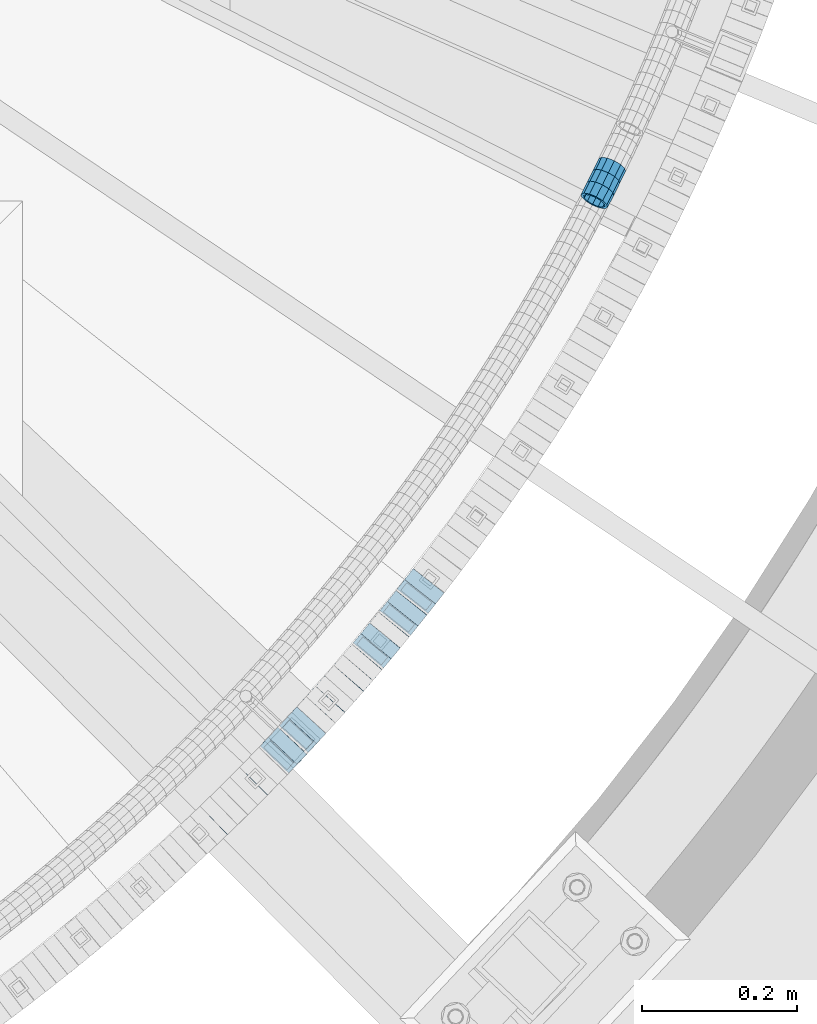
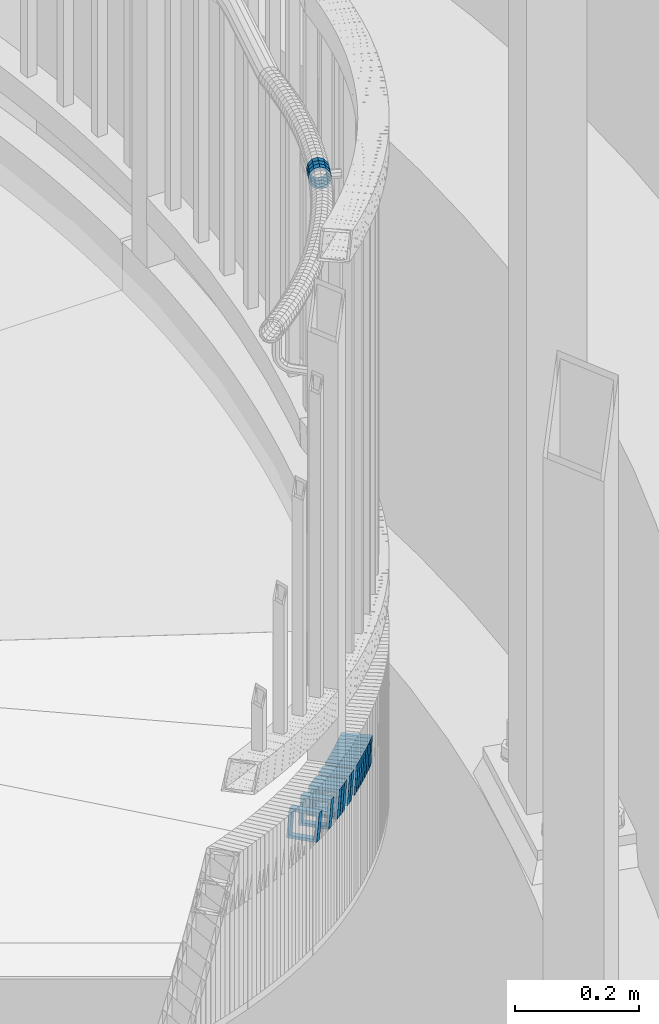
# One storey, part 777 of 975: 19 beams.
"""IFC2X3 building model written with IfcOpenShell, lengths in millimetres."""

from ifc_helpers import new_model, si_unit, frame, origin_with_axes, place, context, subcontext, project, spatial, faceted_brep, material, type_object, element, save


model = new_model("IFC2X3")

# Units and contexts
model_context = context("Model", 3, precision=1e-05, world=origin_with_axes())
body_context = subcontext(model_context, "Body", "Model", "MODEL_VIEW")
ifc_project = project(units=[si_unit("LENGTHUNIT", "METRE", prefix="MILLI"), si_unit("AREAUNIT", "SQUARE_METRE"), si_unit("VOLUMEUNIT", "CUBIC_METRE"), si_unit("MASSUNIT", "GRAM", prefix="KILO"), si_unit("TIMEUNIT", "SECOND"), si_unit("PLANEANGLEUNIT", "RADIAN"), si_unit("SOLIDANGLEUNIT", "STERADIAN"), si_unit("THERMODYNAMICTEMPERATUREUNIT", "DEGREE_CELSIUS"), si_unit("LUMINOUSINTENSITYUNIT", "LUMEN")], contexts=[model_context])

# Site, building, storey
site_placement = place(None, origin_with_axes())
site = spatial("IfcSite", under=ifc_project, at=site_placement, CompositionType="ELEMENT")
building_placement = place(site_placement, origin_with_axes())
building = spatial("IfcBuilding", under=site, at=building_placement, Name="Undefined", CompositionType="ELEMENT")
storey_placement = place(building_placement, origin_with_axes())
storey = spatial("IfcBuildingStorey", under=building, at=storey_placement, Name="Undefined", CompositionType="ELEMENT", Elevation=0.0)

# Beams
ifc_material = material()
beam_type_1 = type_object("IfcBeamType", PredefinedType="NOTDEFINED")
beam_1_placement = place(storey_placement, frame((37215.9977738311, 2133.37891237266, 3207.71060886619), z_axis=(-0.892098047383346, 0.451841868195966, -5.31599653186276e-13), x_axis=(0.429057443980011, 0.847113414960662, -0.313541977985444)))
element("IfcBeam", 1, at=beam_1_placement, inside=storey, type_object=beam_type_1, material=ifc_material, Name="WALL", context=body_context, shape_type="Brep", body=[
    faceted_brep([(-2.1246523829177e-07, -15.367000000002, 0.0), (-1.83998054126278e-07, -13.3082123799541, 7.68350000000009), (18.1793839279671, -13.3082123799522, 7.68350000002465), (18.1793839279671, -15.3669999999947, 2.5465851649642e-11), (-1.06232619145885e-07, -7.68349999999919, 13.3082123799559), (18.1793839279671, -7.68349999999555, 13.3082123799904), (-3.63797880709171e-12, 3.63797880709171e-12, 15.3670000000002), (18.1793839279708, 5.45696821063757e-12, 15.3670000000202), (1.06225343188271e-07, 7.68350000000646, 13.3082123799559), (18.1793839279781, 7.68350000000282, 13.3082123799613), (1.8399441614747e-07, 13.308212379965, 7.68350000000009), (18.1793839279853, 13.3082123799559, 7.68349999998827), (2.12461600312963e-07, 15.3670000000093, 0.0), (18.1793839279926, 15.3669999999984, -2.91038304567337e-11), (1.8399441614747e-07, 13.308212379965, -7.68350000000009), (18.1793839279962, 13.3082123799522, -7.68350000003193), (1.06225343188271e-07, 7.68350000000646, -13.3082123799559), (18.1793839279962, 7.68349999999737, -13.3082123799904), (-3.63797880709171e-12, 3.63797880709171e-12, -15.3670000000002), (18.1793839279962, -1.81898940354586e-12, -15.3670000000202), (-1.06232619145885e-07, -7.68349999999919, -13.3082123799559), (18.1793839279853, -7.68349999999737, -13.3082123799613), (-1.83998054126278e-07, -13.3082123799541, -7.68350000000009), (18.1793839279781, -13.3082123799522, -7.68349999998827), (-2.63386027654633e-07, -19.0500000000029, 0.0), (-2.28097633225843e-07, -16.4977839420972, -9.52499999999964), (18.1793839279744, -16.4977839420917, -9.52499999998327), (18.1793839279671, -19.0499999999938, 3.27418092638254e-11), (-1.31691194837913e-07, -9.52500000000146, -16.4977839420935), (18.179383927989, -9.52499999999964, -16.4977839421044), (-3.63797880709171e-12, 3.63797880709171e-12, -19.0500000000002), (18.1793839279999, -1.81898940354586e-12, -19.050000000032), (1.31687556859106e-07, 9.52500000000509, -16.4977839420935), (18.1793839280035, 9.524999999996, -16.4977839421408), (2.28097633225843e-07, 16.4977839421044, -9.52499999999964), (18.1793839279999, 16.4977839420899, -9.52500000004875), (2.63382389675826e-07, 19.0500000000138, 0.0), (18.1793839279962, 19.0499999999975, -3.27418092638254e-11), (2.28097633225843e-07, 16.4977839421044, 9.52499999999964), (18.1793839279853, 16.4977839420935, 9.52499999998327), (1.31687556859106e-07, 9.52500000000509, 16.4977839420935), (18.1793839279817, 9.52500000000146, 16.4977839420972), (-3.63797880709171e-12, 3.63797880709171e-12, 19.0500000000002), (18.1793839279708, 3.63797880709171e-12, 19.0500000000211), (-1.31691194837913e-07, -9.52500000000146, 16.4977839420935), (18.1793839279635, -9.52499999999418, 16.4977839421335), (-2.28097633225843e-07, -16.4977839420972, 9.52499999999964), (18.1793839279635, -16.4977839420881, 9.52500000004147)], [[[0, 1, 2, 3]], [[1, 4, 5, 2]], [[4, 6, 7, 5]], [[6, 8, 9, 7]], [[8, 10, 11, 9]], [[10, 12, 13, 11]], [[12, 14, 15, 13]], [[14, 16, 17, 15]], [[16, 18, 19, 17]], [[18, 20, 21, 19]], [[20, 22, 23, 21]], [[22, 0, 3, 23]], [[24, 25, 26, 27]], [[25, 28, 29, 26]], [[28, 30, 31, 29]], [[30, 32, 33, 31]], [[32, 34, 35, 33]], [[34, 36, 37, 35]], [[36, 38, 39, 37]], [[38, 40, 41, 39]], [[40, 42, 43, 41]], [[42, 44, 45, 43]], [[44, 46, 47, 45]], [[46, 24, 27, 47]], [[29, 31, 33, 35, 37, 39, 41, 43, 45, 47, 27, 26], [5, 7, 9, 11, 13, 15, 17, 19, 21, 23, 3, 2]], [[46, 44, 42, 40, 38, 36, 34, 32, 30, 28, 25, 24], [22, 20, 18, 16, 14, 12, 10, 8, 6, 4, 1, 0]]]),
])
beam_2_placement = place(storey_placement, frame((37223.9087635079, 2148.82953871151, 3201.97957507688), z_axis=(-0.897875826965735, 0.440248792560067, 1.23243353300495e-10), x_axis=(0.418766152969419, 0.85406254893795, -0.308564533977587)))
element("IfcBeam", 2, at=beam_2_placement, inside=storey, type_object=beam_type_1, material=ifc_material, Name="WALL", context=body_context, shape_type="Brep", body=[
    faceted_brep([(-2.1246523829177e-07, -15.367000000002, 0.0), (-1.83998054126278e-07, -13.3082123799541, 7.68350000000009), (18.1485536614346, -13.3082123799704, 7.68349999991551), (18.1485536614382, -15.3670000000166, -8.73114913702011e-11), (-1.06232619145885e-07, -7.68349999999919, 13.3082123799559), (18.1485536614236, -7.68350000001192, 13.3082123798922), (-3.63797880709171e-12, 3.63797880709171e-12, 15.3670000000002), (18.1485536614127, -1.09139364212751e-11, 15.3669999999547), (1.06225343188271e-07, 7.68350000000646, 13.3082123799559), (18.1485536614018, 7.68349999999191, 13.3082123799322), (1.8399441614747e-07, 13.308212379965, 7.68350000000009), (18.1485536613945, 13.3082123799504, 7.68349999999191), (2.12461600312963e-07, 15.3670000000093, 0.0), (18.1485536613945, 15.3669999999947, -3.63797880709171e-12), (1.8399441614747e-07, 13.308212379965, -7.68350000000009), (18.1485536613982, 13.3082123799504, -7.68350000000646), (1.06225343188271e-07, 7.68350000000646, -13.3082123799559), (18.1485536614091, 7.68349999999009, -13.3082123799832), (-3.63797880709171e-12, 3.63797880709171e-12, -15.3670000000002), (18.1485536614164, -1.09139364212751e-11, -15.3670000000493), (-1.06232619145885e-07, -7.68349999999919, -13.3082123799559), (18.1485536614273, -7.68350000001374, -13.3082123800305), (-1.83998054126278e-07, -13.3082123799541, -7.68350000000009), (18.1485536614346, -13.3082123799722, -7.68350000008286), (-2.63386027654633e-07, -19.0500000000029, 0.0), (-2.28097633225843e-07, -16.4977839420972, -9.52499999999964), (18.1485536614418, -16.4977839421117, -9.52500000009604), (18.1485536614418, -19.0500000000175, -9.82254277914762e-11), (-1.31691194837913e-07, -9.52500000000146, -16.4977839420935), (18.1485536614309, -9.52500000001601, -16.4977839421699), (-3.63797880709171e-12, 3.63797880709171e-12, -19.0500000000002), (18.1485536614164, -1.2732925824821e-11, -19.0500000000502), (1.31687556859106e-07, 9.52500000000509, -16.4977839420935), (18.1485536614055, 9.52499999999054, -16.4977839421153), (2.28097633225843e-07, 16.4977839421044, -9.52499999999964), (18.1485536613945, 16.4977839420881, -9.52500000000146), (2.63382389675826e-07, 19.0500000000138, 0.0), (18.1485536613909, 19.0499999999956, 7.27595761418343e-12), (2.28097633225843e-07, 16.4977839421044, 9.52499999999964), (18.1485536613873, 16.4977839420899, 9.52500000000509), (1.31687556859106e-07, 9.52500000000509, 16.4977839420935), (18.1485536613982, 9.52499999999418, 16.497783942079), (-3.63797880709171e-12, 3.63797880709171e-12, 19.0500000000002), (18.1485536614127, -1.09139364212751e-11, 19.0499999999483), (-1.31691194837913e-07, -9.52500000000146, 16.4977839420935), (18.1485536614236, -9.52500000001419, 16.4977839420171), (-2.28097633225843e-07, -16.4977839420972, 9.52499999999964), (18.1485536614346, -16.4977839421099, 9.52499999991051)], [[[0, 1, 2, 3]], [[1, 4, 5, 2]], [[4, 6, 7, 5]], [[6, 8, 9, 7]], [[8, 10, 11, 9]], [[10, 12, 13, 11]], [[12, 14, 15, 13]], [[14, 16, 17, 15]], [[16, 18, 19, 17]], [[18, 20, 21, 19]], [[20, 22, 23, 21]], [[22, 0, 3, 23]], [[24, 25, 26, 27]], [[25, 28, 29, 26]], [[28, 30, 31, 29]], [[30, 32, 33, 31]], [[32, 34, 35, 33]], [[34, 36, 37, 35]], [[36, 38, 39, 37]], [[38, 40, 41, 39]], [[40, 42, 43, 41]], [[42, 44, 45, 43]], [[44, 46, 47, 45]], [[46, 24, 27, 47]], [[29, 31, 33, 35, 37, 39, 41, 43, 45, 47, 27, 26], [5, 7, 9, 11, 13, 15, 17, 19, 21, 23, 3, 2]], [[46, 44, 42, 40, 38, 36, 34, 32, 30, 28, 25, 24], [22, 20, 18, 16, 14, 12, 10, 8, 6, 4, 1, 0]]]),
])
beam_3_placement = place(storey_placement, frame((37231.492894963, 2164.26291577248, 3196.4013888375), z_axis=(-0.898989869081175, 0.437969422779047, 7.69255166233052e-11), x_axis=(0.416096498926714, 0.854092814849274, -0.312072374944939)))
element("IfcBeam", 3, at=beam_3_placement, inside=storey, type_object=beam_type_1, material=ifc_material, Name="WALL", context=body_context, shape_type="Brep", body=[
    faceted_brep([(-2.1246523829177e-07, -15.367000000002, 0.0), (-1.83998054126278e-07, -13.3082123799541, 7.68350000000009), (18.264993840703, -13.3082123799613, 7.68349999995553), (18.2649938406903, -15.367000000002, -1.81898940354586e-11), (-1.06232619145885e-07, -7.68349999999919, 13.3082123799559), (18.2649938407158, -7.6835000000101, 13.3082123798922), (-3.63797880709171e-12, 3.63797880709171e-12, 15.3670000000002), (18.2649938407194, -1.09139364212751e-11, 15.3669999999292), (1.06225343188271e-07, 7.68350000000646, 13.3082123799559), (18.2649938407158, 7.68349999998827, 13.3082123798995), (1.8399441614747e-07, 13.308212379965, 7.68350000000009), (18.2649938407103, 13.3082123799431, 7.68349999995553), (2.12461600312963e-07, 15.3670000000093, 0.0), (18.2649938406976, 15.3669999999929, -2.5465851649642e-11), (1.8399441614747e-07, 13.308212379965, -7.68350000000009), (18.2649938406885, 13.3082123799504, -7.68350000000282), (1.06225343188271e-07, 7.68350000000646, -13.3082123799559), (18.2649938406812, 7.68349999999919, -13.3082123799395), (-3.63797880709171e-12, 3.63797880709171e-12, -15.3670000000002), (18.2649938406739, 0.0, -15.3669999999802), (-1.06232619145885e-07, -7.68349999999919, -13.3082123799559), (18.2649938406739, -7.68349999999737, -13.3082123799395), (-1.83998054126278e-07, -13.3082123799541, -7.68350000000009), (18.264993840683, -13.3082123799559, -7.68350000000282), (-2.63386027654633e-07, -19.0500000000029, 0.0), (-2.28097633225843e-07, -16.4977839420972, -9.52499999999964), (18.2649938406794, -16.4977839420935, -9.52500000000146), (18.2649938406939, -19.0500000000029, -2.5465851649642e-11), (-1.31691194837913e-07, -9.52500000000146, -16.4977839420935), (18.2649938406703, -9.524999999996, -16.4977839420644), (-3.63797880709171e-12, 3.63797880709171e-12, -19.0500000000002), (18.2649938406666, 1.81898940354586e-12, -19.0499999999665), (1.31687556859106e-07, 9.52500000000509, -16.4977839420935), (18.2649938406739, 9.52499999999964, -16.4977839420717), (2.28097633225843e-07, 16.4977839421044, -9.52499999999964), (18.2649938406848, 16.4977839420899, -9.52499999999418), (2.63382389675826e-07, 19.0500000000138, 0.0), (18.2649938406994, 19.049999999992, -2.91038304567337e-11), (2.28097633225843e-07, 16.4977839421044, 9.52499999999964), (18.2649938407121, 16.4977839420808, 9.52499999994325), (1.31687556859106e-07, 9.52500000000509, 16.4977839420935), (18.264993840723, 9.5249999999869, 16.4977839420244), (-3.63797880709171e-12, 3.63797880709171e-12, 19.0500000000002), (18.2649938407212, -1.09139364212751e-11, 19.0499999999229), (-1.31691194837913e-07, -9.52500000000146, 16.4977839420935), (18.2649938407176, -9.52500000001055, 16.4977839420208), (-2.28097633225843e-07, -16.4977839420972, 9.52499999999964), (18.2649938407067, -16.497783942099, 9.52499999995052)], [[[0, 1, 2, 3]], [[1, 4, 5, 2]], [[4, 6, 7, 5]], [[6, 8, 9, 7]], [[8, 10, 11, 9]], [[10, 12, 13, 11]], [[12, 14, 15, 13]], [[14, 16, 17, 15]], [[16, 18, 19, 17]], [[18, 20, 21, 19]], [[20, 22, 23, 21]], [[22, 0, 3, 23]], [[24, 25, 26, 27]], [[25, 28, 29, 26]], [[28, 30, 31, 29]], [[30, 32, 33, 31]], [[32, 34, 35, 33]], [[34, 36, 37, 35]], [[36, 38, 39, 37]], [[38, 40, 41, 39]], [[40, 42, 43, 41]], [[42, 44, 45, 43]], [[44, 46, 47, 45]], [[46, 24, 27, 47]], [[29, 31, 33, 35, 37, 39, 41, 43, 45, 47, 27, 26], [5, 7, 9, 11, 13, 15, 17, 19, 21, 23, 3, 2]], [[46, 44, 42, 40, 38, 36, 34, 32, 30, 28, 25, 24], [22, 20, 18, 16, 14, 12, 10, 8, 6, 4, 1, 0]]]),
])
beam_type_2 = type_object("IfcBeamType", Name="HSS2X2X.188_TUBES", PredefinedType="NOTDEFINED")
for number, where, z_axis, x_axis, name in (
    (4, (36720.6808139032, 1330.84668870906, 2591.10731278571), (-0.69579521581089, 0.718240222804792, 0.0), (0.684100829257291, 0.662722678249247, -0.304638650114577), "WALL"),
    (5, (36772.0393799773, 1381.34133284551, 2568.20752490063), (-0.712696294593022, 0.701472730527265, 2.40832832787419e-10), (0.668124471232672, 0.678814463236377, -0.304664759106089), "WALL"),
    (6, (36809.7092464069, 1420.04666377854, 2551.0069594265), (-0.723737544936702, 0.690075333604234, 7.89900695963296e-11), (0.657284273884116, 0.689346920878469, -0.304595150946308), "WALL"),
):
    element("IfcBeam", number, at=place(storey_placement, frame(where, z_axis=z_axis, x_axis=x_axis)), inside=storey, type_object=beam_type_2, material=ifc_material, Name=name, ObjectType="HSS2X2X.188_TUBES", context=body_context, shape_type="Brep", body=[
        faceted_brep([(0.0, 20.6374999999753, -20.6375000000298), (0.0, -20.6375000000153, -20.6375000000153), (18.7112265765609, -20.6375000000062, -20.6374999999862), (18.7112265765645, 20.6374999999898, -20.6374999999789), (0.0, -20.6374999999825, 20.6375000000335), (18.7112265765209, -20.6374999999916, 20.6374999999607), (0.0, 20.6375000000116, 20.6375000000189), (18.7112265765245, 20.6375000000025, 20.6374999999716), (0.0, 25.3999999999724, -25.4000000000342), (0.0, 25.400000000016, 25.4000000000196), (18.7112265765172, 25.4000000000051, 25.3999999999614), (18.7112265765718, 25.3999999999887, -25.3999999999724), (0.0, -25.399999999976, 25.4000000000378), (18.7112265765136, -25.3999999999905, 25.3999999999542), (0.0, -25.400000000016, -25.4000000000196), (18.7112265765682, -25.4000000000069, -25.3999999999796)], [[[0, 1, 2, 3]], [[1, 4, 5, 2]], [[4, 6, 7, 5]], [[6, 0, 3, 7]], [[8, 9, 10, 11]], [[9, 12, 13, 10]], [[12, 14, 15, 13]], [[14, 8, 11, 15]], [[13, 15, 11, 10], [5, 7, 3, 2]], [[14, 12, 9, 8], [6, 4, 1, 0]]]),
    ])
beam_4_placement = place(storey_placement, frame((36822.3767102261, 1433.15899254637, 2545.30583006654), z_axis=(-0.734588421928499, 0.678512969933956, 0.0), x_axis=(0.64630149998239, 0.699714846980909, -0.304456078991693)))
element("IfcBeam", 7, at=beam_4_placement, inside=storey, type_object=beam_type_2, material=ifc_material, Name="WALL", ObjectType="HSS2X2X.188_TUBES", context=body_context, shape_type="Brep", body=[
    faceted_brep([(0.0, 20.6374999999753, -20.6375000000298), (0.0, -20.6375000000153, -20.6375000000153), (18.724849799155, -20.6375000000171, -20.6374999999425), (18.7248497991204, 20.6374999999989, -20.6375000000007), (0.0, -20.6374999999825, 20.6375000000335), (18.7248497991168, -20.6374999999953, 20.6375000000007), (0.0, 20.6375000000116, 20.6375000000189), (18.724849799084, 20.6375000000226, 20.6374999999498), (0.0, 25.3999999999724, -25.4000000000342), (0.0, 25.400000000016, 25.4000000000196), (18.7248497990731, 25.4000000000269, 25.399999999936), (18.7248497991204, 25.3999999999978, -25.3999999999978), (0.0, -25.399999999976, 25.4000000000378), (18.7248497991186, -25.3999999999942, 25.4000000000051), (0.0, -25.400000000016, -25.4000000000196), (18.7248497991604, -25.4000000000233, -25.3999999999323)], [[[0, 1, 2, 3]], [[1, 4, 5, 2]], [[4, 6, 7, 5]], [[6, 0, 3, 7]], [[8, 9, 10, 11]], [[9, 12, 13, 10]], [[12, 14, 15, 13]], [[14, 8, 11, 15]], [[13, 15, 11, 10], [5, 7, 3, 2]], [[14, 12, 9, 8], [6, 4, 1, 0]]]),
])
beam_5_placement = place(storey_placement, frame((36834.5829369843, 1446.33124225262, 2539.59662764212), z_axis=(-0.737154140366779, 0.675724628336214, 0.0), x_axis=(0.643890345944895, 0.702425832939839, -0.303320245974015)))
element("IfcBeam", 8, at=beam_5_placement, inside=storey, type_object=beam_type_2, material=ifc_material, Name="WALL", ObjectType="HSS2X2X.188_TUBES", context=body_context, shape_type="Brep", body=[
    faceted_brep([(0.0, 20.6374999999753, -20.6375000000298), (0.0, -20.6375000000153, -20.6375000000153), (18.7853666454903, -20.6375000000535, -20.6375000000326), (18.785366645363, 20.6374999999862, -20.6375000000044), (0.0, -20.6374999999825, 20.6375000000335), (18.785366645352, -20.6375000000007, 20.6374999999989), (0.0, 20.6375000000116, 20.6375000000189), (18.7853666453102, 20.6375000000025, 20.6374999999753), (0.0, 25.3999999999724, -25.4000000000342), (0.0, 25.400000000016, 25.4000000000196), (18.7853666452065, 25.4000000000451, 25.4000000000351), (18.7853666453739, 25.3999999999833, -25.400000000006), (0.0, -25.399999999976, 25.4000000000378), (18.7853666497213, -25.399999993424, 25.3999999995158), (0.0, -25.400000000016, -25.4000000000196), (18.7853666455194, -25.4000000000633, -25.4000000000406)], [[[0, 1, 2, 3]], [[1, 4, 5, 2]], [[4, 6, 7, 5]], [[6, 0, 3, 7]], [[8, 9, 10, 11]], [[9, 12, 13, 10]], [[12, 14, 15, 13]], [[14, 8, 11, 15]], [[13, 15, 11, 10], [5, 7, 3, 2]], [[14, 12, 9, 8], [6, 4, 1, 0]]]),
])
beam_6_placement = place(storey_placement, frame((36858.864435877, 1472.84051337354, 2528.09579487004), z_axis=(-0.742460834710519, 0.669889475153148, -9.78848220256625e-11), x_axis=(0.638352058026851, 0.707506864029715, -0.303217228012726)))
element("IfcBeam", 9, at=beam_6_placement, inside=storey, type_object=beam_type_2, material=ifc_material, Name="WALL", ObjectType="HSS2X2X.188_TUBES", context=body_context, shape_type="Brep", body=[
    faceted_brep([(0.0, 20.6374999999753, -20.6375000000298), (0.0, -20.6375000000153, -20.6375000000153), (18.8047866246379, -20.6374999999916, -20.6375000000298), (18.8047866247143, 20.6374999999844, -20.6374999999643), (0.0, -20.6374999999825, 20.6375000000335), (18.8047866247107, -20.6375000000189, 20.6375000000407), (0.0, 20.6375000000116, 20.6375000000189), (18.8047866247907, 20.6374999999589, 20.6375000001026), (0.0, 25.3999999999724, -25.4000000000342), (0.0, 25.400000000016, 25.4000000000196), (18.8047866248016, 25.3999999999542, 25.4000000001142), (18.8047866247143, 25.3999999999851, -25.3999999999651), (0.0, -25.399999999976, 25.4000000000378), (18.8047866247107, -25.4000000000196, 25.4000000000415), (0.0, -25.400000000016, -25.4000000000196), (18.8047866246197, -25.3999999999887, -25.4000000000378)], [[[0, 1, 2, 3]], [[1, 4, 5, 2]], [[4, 6, 7, 5]], [[6, 0, 3, 7]], [[8, 9, 10, 11]], [[9, 12, 13, 10]], [[12, 14, 15, 13]], [[14, 8, 11, 15]], [[13, 15, 11, 10], [5, 7, 3, 2]], [[14, 12, 9, 8], [6, 4, 1, 0]]]),
])
beam_7_placement = place(storey_placement, frame((36871.1226756406, 1486.29032781496, 2522.40308609124), z_axis=(-0.750491265131667, 0.660880368115947, 0.0), x_axis=(0.629577376938466, 0.714943800930165, -0.304117884970302)))
element("IfcBeam", 10, at=beam_7_placement, inside=storey, type_object=beam_type_2, material=ifc_material, Name="WALL", ObjectType="HSS2X2X.188_TUBES", context=body_context, shape_type="Brep", body=[
    faceted_brep([(0.0, 20.6374999999753, -20.6375000000298), (0.0, -20.6375000000153, -20.6375000000153), (18.7416648140024, -20.6375000000153, -20.6374999999825), (18.7416648139188, 20.6375000000189, -20.6375000000298), (0.0, -20.6374999999825, 20.6375000000335), (18.7416648140097, -20.6375000000189, 20.6375000000226), (0.0, 20.6375000000116, 20.6375000000189), (18.741664813926, 20.6375000000153, 20.6374999999753), (0.0, 25.3999999999724, -25.4000000000342), (0.0, 25.400000000016, 25.4000000000196), (18.7416648139224, 25.4000000000196, 25.3999999999687), (18.7416648139042, 25.4000000000233, -25.4000000000378), (0.0, -25.399999999976, 25.4000000000378), (18.7416648140133, -25.4000000000215, 25.4000000000269), (0.0, -25.400000000016, -25.4000000000196), (18.7416648140133, -25.4000000000196, -25.399999999976)], [[[0, 1, 2, 3]], [[1, 4, 5, 2]], [[4, 6, 7, 5]], [[6, 0, 3, 7]], [[8, 9, 10, 11]], [[9, 12, 13, 10]], [[12, 14, 15, 13]], [[14, 8, 11, 15]], [[13, 15, 11, 10], [5, 7, 3, 2]], [[14, 12, 9, 8], [6, 4, 1, 0]]]),
])
beam_8_placement = place(storey_placement, frame((36894.903106689, 1513.20412529721, 2510.90189390617), z_axis=(-0.755689083086772, 0.654930538075203, 0.0), x_axis=(0.623940104870515, 0.719930889850585, -0.303970819936908)))
element("IfcBeam", 11, at=beam_8_placement, inside=storey, type_object=beam_type_2, material=ifc_material, Name="WALL", ObjectType="HSS2X2X.188_TUBES", context=body_context, shape_type="Brep", body=[
    faceted_brep([(0.0, 20.6374999999753, -20.6375000000298), (0.0, -20.6375000000153, -20.6375000000153), (18.7547327359644, -20.6374999999844, -20.6375000000553), (18.7547327359898, 20.6375000000171, -20.6375000000335), (0.0, -20.6374999999825, 20.6375000000335), (18.7547327360044, -20.6374999999953, 20.6374999999898), (0.0, 20.6375000000116, 20.6375000000189), (18.7547327360262, 20.6375000000062, 20.6375000000116), (0.0, 25.3999999999724, -25.4000000000342), (0.0, 25.400000000016, 25.4000000000196), (18.7547327360371, 25.4000000000033, 25.4000000000124), (18.7547327359898, 25.4000000000178, -25.4000000000342), (0.0, -25.399999999976, 25.4000000000378), (18.7547327360044, -25.399999999996, 25.3999999999869), (0.0, -25.400000000016, -25.4000000000196), (18.7547327359498, -25.3999999999814, -25.4000000000597)], [[[0, 1, 2, 3]], [[1, 4, 5, 2]], [[4, 6, 7, 5]], [[6, 0, 3, 7]], [[8, 9, 10, 11]], [[9, 12, 13, 10]], [[12, 14, 15, 13]], [[14, 8, 11, 15]], [[13, 15, 11, 10], [5, 7, 3, 2]], [[14, 12, 9, 8], [6, 4, 1, 0]]]),
])
beam_9_placement = place(storey_placement, frame((36906.8826352718, 1526.89417480842, 2505.19109764935), z_axis=(-0.763174944777975, 0.646191924789482, -2.3686789063504e-10), x_axis=(0.61588965409582, 0.727386918113142, -0.302635433047084)))
element("IfcBeam", 12, at=beam_9_placement, inside=storey, type_object=beam_type_2, material=ifc_material, Name="WALL", ObjectType="HSS2X2X.188_TUBES", context=body_context, shape_type="Brep", body=[
    faceted_brep([(0.0, 20.6374999999753, -20.6375000000298), (0.0, -20.6375000000153, -20.6375000000153), (18.8332159191086, -20.6374999999916, -20.6375000000153), (18.8332159190923, 20.6375000000062, -20.6375000000335), (0.0, -20.6374999999825, 20.6375000000335), (18.8332159191377, -20.6375000000062, 20.6375000000335), (0.0, 20.6375000000116, 20.6375000000189), (18.8332159191141, 20.6374999999916, 20.6375000000116), (0.0, 25.3999999999724, -25.4000000000342), (0.0, 25.400000000016, 25.4000000000196), (18.8332159191159, 25.3999999999905, 25.4000000000124), (18.8332159190886, 25.4000000000069, -25.4000000000415), (0.0, -25.399999999976, 25.4000000000378), (18.8332159191395, -25.4000000000069, 25.4000000000378), (0.0, -25.400000000016, -25.4000000000196), (18.8332159191104, -25.3999999999905, -25.400000000016)], [[[0, 1, 2, 3]], [[1, 4, 5, 2]], [[4, 6, 7, 5]], [[6, 0, 3, 7]], [[8, 9, 10, 11]], [[9, 12, 13, 10]], [[12, 14, 15, 13]], [[14, 8, 11, 15]], [[13, 15, 11, 10], [5, 7, 3, 2]], [[14, 12, 9, 8], [6, 4, 1, 0]]]),
])
beam_10_placement = place(storey_placement, frame((36918.4826175393, 1540.54278121212, 2499.53848619024), z_axis=(-0.765925091094036, 0.642929821078936, 0.0), x_axis=(0.611581013932087, 0.728579120919091, -0.308449554965744)))
element("IfcBeam", 13, at=beam_10_placement, inside=storey, type_object=beam_type_2, material=ifc_material, Name="WALL", ObjectType="HSS2X2X.188_TUBES", context=body_context, shape_type="Brep", body=[
    faceted_brep([(0.0, 20.6374999999753, -20.6375000000298), (0.0, -20.6375000000153, -20.6375000000153), (18.8047866246379, -20.6374999999916, -20.6375000000298), (18.8047866247143, 20.6374999999844, -20.6374999999643), (0.0, -20.6374999999825, 20.6375000000335), (18.8047866247107, -20.6375000000189, 20.6375000000407), (0.0, 20.6375000000116, 20.6375000000189), (18.8047866247907, 20.6374999999589, 20.6375000001026), (0.0, 25.3999999999724, -25.4000000000342), (0.0, 25.400000000016, 25.4000000000196), (18.8047866248016, 25.3999999999542, 25.4000000001142), (18.8047866247143, 25.3999999999851, -25.3999999999651), (0.0, -25.399999999976, 25.4000000000378), (18.8047866247107, -25.4000000000196, 25.4000000000415), (0.0, -25.400000000016, -25.4000000000196), (18.8047866246197, -25.3999999999887, -25.4000000000378)], [[[0, 1, 2, 3]], [[1, 4, 5, 2]], [[4, 6, 7, 5]], [[6, 0, 3, 7]], [[8, 9, 10, 11]], [[9, 12, 13, 10]], [[12, 14, 15, 13]], [[14, 8, 11, 15]], [[13, 15, 11, 10], [5, 7, 3, 2]], [[14, 12, 9, 8], [6, 4, 1, 0]]]),
])
beam_11_placement = place(storey_placement, frame((36930.1407195015, 1554.37977625716, 2493.70713608023), z_axis=(-0.768680983961865, 0.639632351351477, 1.51630047184881e-10), x_axis=(0.609233796907723, 0.732149387889087, -0.304616897953864)))
element("IfcBeam", 14, at=beam_11_placement, inside=storey, type_object=beam_type_2, material=ifc_material, Name="WALL", ObjectType="HSS2X2X.188_TUBES", context=body_context, shape_type="Brep", body=[
    faceted_brep([(0.0, 20.6374999999753, -20.6375000000298), (0.0, -20.6375000000153, -20.6375000000153), (18.7112265765609, -20.6375000000062, -20.6374999999862), (18.7112265765645, 20.6374999999898, -20.6374999999789), (0.0, -20.6374999999825, 20.6375000000335), (18.7112265765209, -20.6374999999916, 20.6374999999607), (0.0, 20.6375000000116, 20.6375000000189), (18.7112265765245, 20.6375000000025, 20.6374999999716), (0.0, 25.3999999999724, -25.4000000000342), (0.0, 25.400000000016, 25.4000000000196), (18.7112265765172, 25.4000000000051, 25.3999999999614), (18.7112265765718, 25.3999999999887, -25.3999999999724), (0.0, -25.399999999976, 25.4000000000378), (18.7112265765136, -25.3999999999905, 25.3999999999542), (0.0, -25.400000000016, -25.4000000000196), (18.7112265765682, -25.4000000000069, -25.3999999999796)], [[[0, 1, 2, 3]], [[1, 4, 5, 2]], [[4, 6, 7, 5]], [[6, 0, 3, 7]], [[8, 9, 10, 11]], [[9, 12, 13, 10]], [[12, 14, 15, 13]], [[14, 8, 11, 15]], [[13, 15, 11, 10], [5, 7, 3, 2]], [[14, 12, 9, 8], [6, 4, 1, 0]]]),
])
beam_12_placement = place(storey_placement, frame((36941.6590922166, 1568.13626903687, 2488.02699026868), z_axis=(-0.773213238606774, 0.634146109065745, 1.07743744592881e-10), x_axis=(0.603512601119888, 0.735861856146166, -0.307050271060987)))
element("IfcBeam", 15, at=beam_12_placement, inside=storey, type_object=beam_type_2, material=ifc_material, Name="WALL", ObjectType="HSS2X2X.188_TUBES", context=body_context, shape_type="Brep", body=[
    faceted_brep([(0.0, 20.6374999999753, -20.6375000000298), (0.0, -20.6375000000153, -20.6375000000153), (18.891267824034, -20.6375000000153, -20.6374999999971), (18.891267824034, 20.6375000000025, -20.637500000008), (0.0, -20.6374999999825, 20.6375000000335), (18.8912678240486, -20.6374999999989, 20.6375000000153), (0.0, 20.6375000000116, 20.6375000000189), (18.8912678240449, 20.6375000000189, 20.6375000000007), (0.0, 25.3999999999724, -25.4000000000342), (0.0, 25.400000000016, 25.4000000000196), (18.8912678240467, 25.4000000000215, 25.4000000000051), (18.8912678240304, 25.4000000000033, -25.4000000000124), (0.0, -25.399999999976, 25.4000000000378), (18.8912678240504, -25.3999999999996, 25.400000000016), (0.0, -25.400000000016, -25.4000000000196), (18.891267824034, -25.4000000000178, -25.3999999999978)], [[[0, 1, 2, 3]], [[1, 4, 5, 2]], [[4, 6, 7, 5]], [[6, 0, 3, 7]], [[8, 9, 10, 11]], [[9, 12, 13, 10]], [[12, 14, 15, 13]], [[14, 8, 11, 15]], [[13, 15, 11, 10], [5, 7, 3, 2]], [[14, 12, 9, 8], [6, 4, 1, 0]]]),
])
beam_13_placement = place(storey_placement, frame((36953.2960182316, 1582.22110720077, 2482.20361280791), z_axis=(-0.778677881834259, 0.627423904822021, 1.10485416371376e-11), x_axis=(0.597692588146393, 0.741779194181727, -0.304182835074522)))
element("IfcBeam", 16, at=beam_13_placement, inside=storey, type_object=beam_type_2, material=ifc_material, Name="WALL", ObjectType="HSS2X2X.188_TUBES", context=body_context, shape_type="Brep", body=[
    faceted_brep([(0.0, 20.6374999999753, -20.6375000000298), (0.0, -20.6375000000153, -20.6375000000153), (18.7416648140024, -20.6375000000153, -20.6374999999825), (18.7416648139188, 20.6375000000189, -20.6375000000298), (0.0, -20.6374999999825, 20.6375000000335), (18.7416648140097, -20.6375000000189, 20.6375000000226), (0.0, 20.6375000000116, 20.6375000000189), (18.741664813926, 20.6375000000153, 20.6374999999753), (0.0, 25.3999999999724, -25.4000000000342), (0.0, 25.400000000016, 25.4000000000196), (18.7416648139224, 25.4000000000196, 25.3999999999687), (18.7416648139042, 25.4000000000233, -25.4000000000378), (0.0, -25.399999999976, 25.4000000000378), (18.7416648140133, -25.4000000000215, 25.4000000000269), (0.0, -25.400000000016, -25.4000000000196), (18.7416648140133, -25.4000000000196, -25.399999999976)], [[[0, 1, 2, 3]], [[1, 4, 5, 2]], [[4, 6, 7, 5]], [[6, 0, 3, 7]], [[8, 9, 10, 11]], [[9, 12, 13, 10]], [[12, 14, 15, 13]], [[14, 8, 11, 15]], [[13, 15, 11, 10], [5, 7, 3, 2]], [[14, 12, 9, 8], [6, 4, 1, 0]]]),
])
beam_14_placement = place(storey_placement, frame((36964.591812875, 1596.19731911561, 2476.49389080145), z_axis=(-0.780868809052787, 0.624695048042229, 0.0), x_axis=(0.595332147207138, 0.744165184258885, -0.302981539105402)))
element("IfcBeam", 17, at=beam_14_placement, inside=storey, type_object=beam_type_2, material=ifc_material, Name="WALL", ObjectType="HSS2X2X.188_TUBES", context=body_context, shape_type="Brep", body=[
    faceted_brep([(0.0, 20.6374999999753, -20.6375000000298), (0.0, -20.6375000000153, -20.6375000000153), (18.8066477608099, -20.6374999999862, -20.6375000000116), (18.8066477608172, 20.6375000000062, -20.6374999999971), (0.0, -20.6374999999825, 20.6375000000335), (18.8066477608463, -20.6375000000062, 20.6375000000407), (0.0, 20.6375000000116, 20.6375000000189), (18.8066477608536, 20.6374999999844, 20.637500000048), (0.0, 25.3999999999724, -25.4000000000342), (0.0, 25.400000000016, 25.4000000000196), (18.8066477608591, 25.3999999999814, 25.400000000056), (18.8066477608154, 25.4000000000051, -25.4000000000015), (0.0, -25.399999999976, 25.4000000000378), (18.8066477608518, -25.4000000000087, 25.4000000000451), (0.0, -25.400000000016, -25.4000000000196), (18.8066477608081, -25.3999999999851, -25.4000000000196)], [[[0, 1, 2, 3]], [[1, 4, 5, 2]], [[4, 6, 7, 5]], [[6, 0, 3, 7]], [[8, 9, 10, 11]], [[9, 12, 13, 10]], [[12, 14, 15, 13]], [[14, 8, 11, 15]], [[13, 15, 11, 10], [5, 7, 3, 2]], [[14, 12, 9, 8], [6, 4, 1, 0]]]),
])
for number, where, z_axis, x_axis, name in (
    (18, (36975.8909853627, 1610.22458631394, 2470.83105868179), (-0.785737878228026, 0.618559606438797, -6.58492353977634e-11), (0.588579954160606, 0.747655617203979, -0.30754628208391), "WALL"),
    (19, (36986.9909853627, 1624.32458631394, 2465.03105868179), (-0.785737878228026, 0.618559606438797, -6.58492353977634e-11), (0.588579954160606, 0.747655617203979, -0.30754628208391), "WALL"),
):
    element("IfcBeam", number, at=place(storey_placement, frame(where, z_axis=z_axis, x_axis=x_axis)), inside=storey, type_object=beam_type_2, material=ifc_material, Name=name, ObjectType="HSS2X2X.188_TUBES", context=body_context, shape_type="Brep", body=[
        faceted_brep([(0.0, 20.6374999999753, -20.6375000000298), (0.0, -20.6375000000153, -20.6375000000153), (18.8565638439322, -20.6375000000116, -20.6374999999643), (18.8565638439395, 20.637499999988, -20.6374999999534), (0.0, -20.6374999999825, 20.6375000000335), (18.856563843914, -20.6374999999953, 20.6375000000116), (0.0, 20.6375000000116, 20.6375000000189), (18.8565638439177, 20.6375000000007, 20.6375000000226), (0.0, 25.3999999999724, -25.4000000000342), (0.0, 25.400000000016, 25.4000000000196), (18.8565638439177, 25.4000000000033, 25.4000000000233), (18.8565638439468, 25.3999999999851, -25.3999999999505), (0.0, -25.399999999976, 25.4000000000378), (18.8565638439104, -25.399999999996, 25.4000000000087), (0.0, -25.400000000016, -25.4000000000196), (18.8565638439395, -25.4000000000124, -25.3999999999614)], [[[0, 1, 2, 3]], [[1, 4, 5, 2]], [[4, 6, 7, 5]], [[6, 0, 3, 7]], [[8, 9, 10, 11]], [[9, 12, 13, 10]], [[12, 14, 15, 13]], [[14, 8, 11, 15]], [[13, 15, 11, 10], [5, 7, 3, 2]], [[14, 12, 9, 8], [6, 4, 1, 0]]]),
    ])

save(model, "model.ifc")
